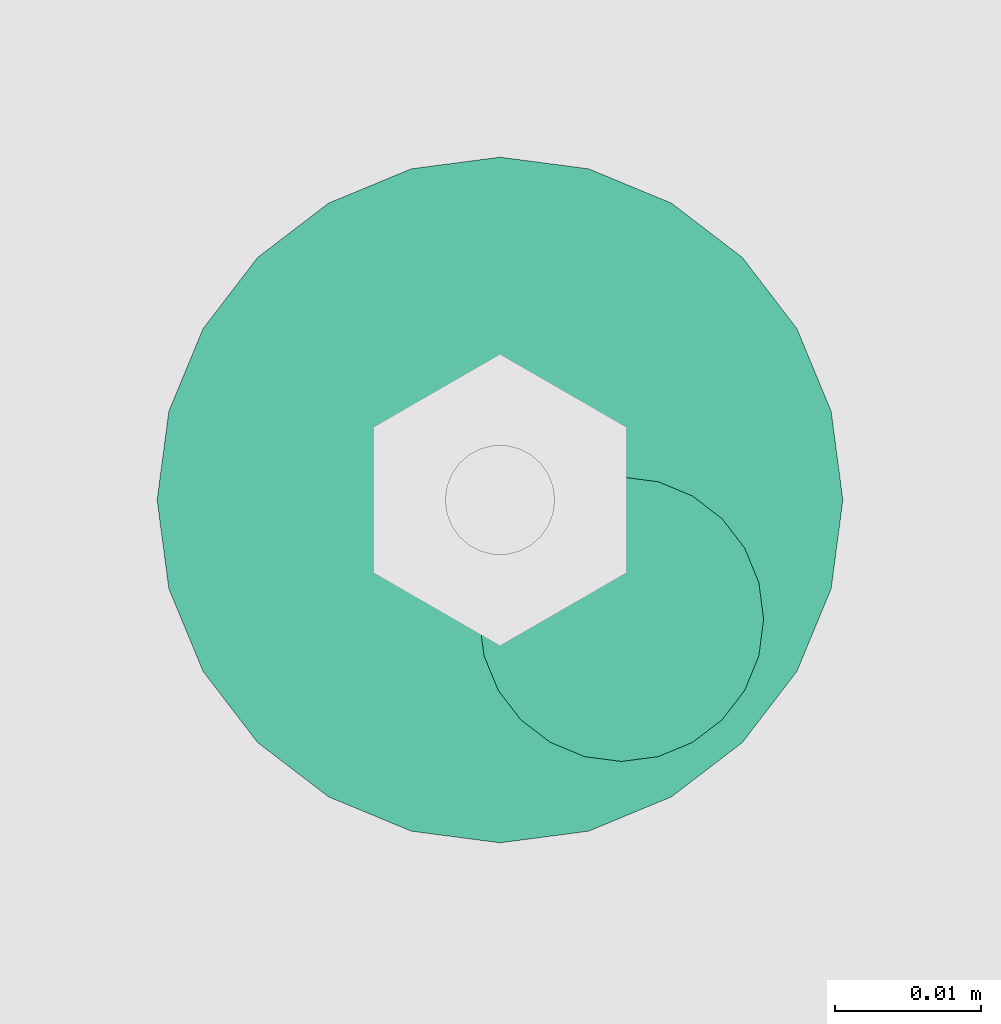
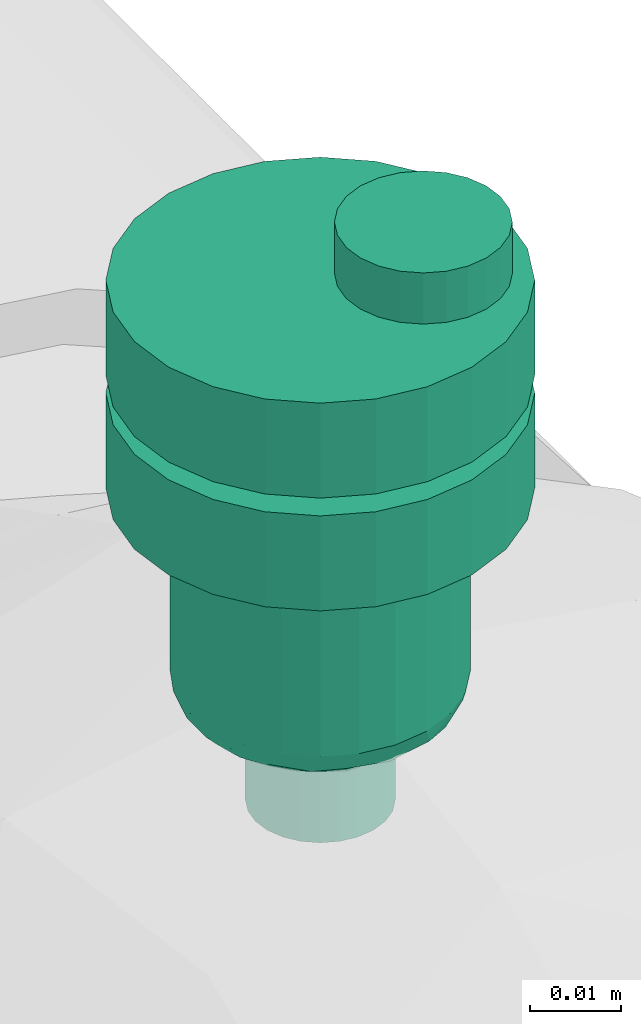
# One storey, part 3 of 6: 1 flow controller.
"""IFC2X3 building model written with IfcOpenShell, lengths in millimetres."""

from ifc_helpers import new_model, entity, si_unit, converted_unit, derived_unit, direction, frame, origin, place, context, subcontext, project, spatial, faceted_brep, source, transform, mapped, material, type_object, type_shapes, element, save


model = new_model("IFC2X3")

# Units and contexts
model_context = context("Model", 3, precision=0.01, world=origin(), true_north=direction((6.12303176911189e-17, 1.0)))
body_context = subcontext(model_context, "Body", "Model", "MODEL_VIEW")
ifc_project = project(units=[si_unit("LENGTHUNIT", "METRE", prefix="MILLI"), si_unit("AREAUNIT", "SQUARE_METRE"), si_unit("VOLUMEUNIT", "CUBIC_METRE"), converted_unit("PLANEANGLEUNIT", "DEGREE", entity("IfcRatioMeasure", 0.0174532925199433), si_unit("PLANEANGLEUNIT", "RADIAN"), dimensions=[0, 0, 0, 0, 0, 0, 0]), si_unit("MASSUNIT", "GRAM", prefix="KILO"), derived_unit("MASSDENSITYUNIT", [(si_unit("MASSUNIT", "GRAM", prefix="KILO"), 1), (si_unit("LENGTHUNIT", "METRE"), -3)]), derived_unit("MOMENTOFINERTIAUNIT", [(si_unit("LENGTHUNIT", "METRE"), 4)]), si_unit("TIMEUNIT", "SECOND"), si_unit("FREQUENCYUNIT", "HERTZ"), si_unit("THERMODYNAMICTEMPERATUREUNIT", "DEGREE_CELSIUS"), derived_unit("THERMALTRANSMITTANCEUNIT", [(si_unit("MASSUNIT", "GRAM", prefix="KILO"), 1), (si_unit("THERMODYNAMICTEMPERATUREUNIT", "KELVIN"), -1), (si_unit("TIMEUNIT", "SECOND"), -3)]), derived_unit("VOLUMETRICFLOWRATEUNIT", [(si_unit("LENGTHUNIT", "METRE"), 3), (si_unit("TIMEUNIT", "SECOND"), -1)]), derived_unit("MASSFLOWRATEUNIT", [(si_unit("MASSUNIT", "GRAM", prefix="KILO"), 1), (si_unit("TIMEUNIT", "SECOND"), -1)]), derived_unit("ROTATIONALFREQUENCYUNIT", [(si_unit("TIMEUNIT", "SECOND"), -1)]), si_unit("ELECTRICCURRENTUNIT", "AMPERE"), si_unit("ELECTRICVOLTAGEUNIT", "VOLT"), si_unit("POWERUNIT", "WATT"), si_unit("FORCEUNIT", "NEWTON", prefix="KILO"), si_unit("ILLUMINANCEUNIT", "LUX"), si_unit("LUMINOUSFLUXUNIT", "LUMEN"), si_unit("LUMINOUSINTENSITYUNIT", "CANDELA"), derived_unit("USERDEFINED", [(si_unit("MASSUNIT", "GRAM", prefix="KILO"), -1), (si_unit("LENGTHUNIT", "METRE"), -2), (si_unit("TIMEUNIT", "SECOND"), 3), (si_unit("LUMINOUSFLUXUNIT", "LUMEN"), 1)]), derived_unit("LINEARVELOCITYUNIT", [(si_unit("LENGTHUNIT", "METRE"), 1), (si_unit("TIMEUNIT", "SECOND"), -1)]), si_unit("PRESSUREUNIT", "PASCAL"), derived_unit("USERDEFINED", [(si_unit("LENGTHUNIT", "METRE"), -2), (si_unit("MASSUNIT", "GRAM", prefix="KILO"), 1), (si_unit("TIMEUNIT", "SECOND"), -2)]), derived_unit("LINEARFORCEUNIT", [(si_unit("MASSUNIT", "GRAM", prefix="KILO"), 1), (si_unit("LENGTHUNIT", "METRE"), 1), (si_unit("TIMEUNIT", "SECOND"), -2), (si_unit("LENGTHUNIT", "METRE"), -1)]), derived_unit("PLANARFORCEUNIT", [(si_unit("MASSUNIT", "GRAM", prefix="KILO"), 1), (si_unit("LENGTHUNIT", "METRE"), 1), (si_unit("TIMEUNIT", "SECOND"), -2), (si_unit("LENGTHUNIT", "METRE"), -2)])], contexts=[model_context])

# Site, building, storey
site_placement = place(None, origin())
site = spatial("IfcSite", under=ifc_project, at=site_placement, CompositionType="ELEMENT")
building_placement = place(site_placement, origin())
building = spatial("IfcBuilding", under=site, at=building_placement, CompositionType="ELEMENT")
storey_placement = place(building_placement, origin())
storey = spatial("IfcBuildingStorey", under=building, at=storey_placement, Name="01", CompositionType="ELEMENT", Elevation=0.0)

# Flow controller
ifc_material = material()
valve_type = type_object("IfcValveType", PredefinedType="NOTDEFINED", material=ifc_material)
shared_shape = source(origin(), body_context, "Body", "Brep", [
    faceted_brep([(-6.86, -13.27, -15.58), (-5.66, -12.77, -15.58), (-5.66, -12.77, -13.2), (-6.86, -13.27, -13.2), (-6.86, -13.27, -0.5), (-5.66, -12.77, -0.5), (-5.66, -12.77, 2.49), (-6.86, -13.27, 2.49), (-8.16, -13.44, -15.58), (-8.16, -13.44, -13.2), (-8.16, -13.44, -0.5), (-8.16, -13.44, 2.49), (-3.83, -10.94, -15.58), (-3.33, -9.74, -15.58), (-3.33, -9.74, -13.2), (-3.83, -10.94, -13.2), (-3.83, -10.94, -0.5), (-3.33, -9.74, -0.5), (-3.33, -9.74, 2.49), (-3.83, -10.94, 2.49), (-4.62, -11.98, -15.58), (-4.62, -11.98, -13.2), (-4.62, -11.98, -0.5), (-4.62, -11.98, 2.49), (-3.16, -8.44, -13.2), (-3.16, -8.44, -15.58), (-3.16, -8.44, 2.49), (-3.16, -8.44, -0.5), (-3.83, -5.94, -15.58), (-4.62, -4.91, -15.58), (-4.62, -4.91, -13.2), (-3.83, -5.94, -13.2), (-3.83, -5.94, -0.5), (-4.62, -4.91, -0.5), (-4.62, -4.91, 2.49), (-3.83, -5.94, 2.49), (-3.33, -7.15, -15.58), (-3.33, -7.15, -13.2), (-3.33, -7.15, -0.5), (-3.33, -7.15, 2.49), (-6.86, -3.61, -15.58), (-8.16, -3.44, -15.58), (-8.16, -3.44, -13.2), (-6.86, -3.61, -13.2), (-6.86, -3.61, -0.5), (-8.16, -3.44, -0.5), (-8.16, -3.44, 2.49), (-6.86, -3.61, 2.49), (-5.66, -4.11, -15.58), (-5.66, -4.11, -13.2), (-5.66, -4.11, -0.5), (-5.66, -4.11, 2.49), (-9.45, -3.61, -0.5), (-9.45, -3.61, 2.49), (-9.45, -3.61, -15.58), (-9.45, -3.61, -13.2), (-10.66, -4.11, -0.5), (-10.66, -4.11, 2.49), (-10.66, -4.11, -15.58), (-10.66, -4.11, -13.2), (-12.49, -5.94, 2.49), (-11.69, -4.91, 2.49), (-11.69, -4.91, -0.5), (-12.49, -5.94, -0.5), (-11.69, -4.91, -15.58), (-12.49, -5.94, -15.58), (-12.49, -5.94, -13.2), (-11.69, -4.91, -13.2), (-12.99, -7.15, 2.49), (-12.99, -7.15, -0.5), (-12.99, -7.15, -15.58), (-12.99, -7.15, -13.2), (-13.16, -8.44, 2.49), (-13.16, -8.44, -0.5), (-13.16, -8.44, -13.2), (-13.16, -8.44, -15.58), (-12.49, -10.94, -0.5), (-12.49, -10.94, 2.49), (-12.99, -9.74, 2.49), (-12.99, -9.74, -0.5), (-12.99, -9.74, -15.58), (-12.49, -10.94, -15.58), (-12.49, -10.94, -13.2), (-12.99, -9.74, -13.2), (-11.69, -11.98, -0.5), (-11.69, -11.98, 2.49), (-11.69, -11.98, -15.58), (-11.69, -11.98, -13.2), (-9.45, -13.27, 2.49), (-10.66, -12.77, 2.49), (-10.66, -12.77, -0.5), (-9.45, -13.27, -0.5), (-10.66, -12.77, -15.58), (-9.45, -13.27, -15.58), (-9.45, -13.27, -13.2), (-10.66, -12.77, -13.2), (6.08, -22.7, -0.5), (0.0, -23.5, -0.5), (11.75, -20.35, -0.5), (16.62, -16.62, -0.5), (20.35, -11.75, -0.5), (22.7, -6.08, -0.5), (23.5, 0.0, -0.5), (22.7, 6.08, -0.5), (20.35, 11.75, -0.5), (16.62, 16.62, -0.5), (11.75, 20.35, -0.5), (6.08, 22.7, -0.5), (0.0, 23.5, -0.5), (-6.08, 22.7, -0.5), (-11.75, 20.35, -0.5), (-16.62, 16.62, -0.5), (-20.35, 11.75, -0.5), (-22.7, 6.08, -0.5), (-23.5, 0.0, -0.5), (-22.7, -6.08, -0.5), (-20.35, -11.75, -0.5), (-16.62, -16.62, -0.5), (-11.75, -20.35, -0.5), (-6.08, -22.7, -0.5), (11.75, 20.35, -13.2), (6.08, 22.7, -13.2), (16.62, 16.62, -13.2), (20.35, 11.75, -13.2), (22.7, 6.08, -13.2), (23.5, 0.0, -13.2), (22.7, -6.08, -13.2), (20.35, -11.75, -13.2), (16.62, -16.62, -13.2), (11.75, -20.35, -13.2), (6.08, -22.7, -13.2), (0.0, -23.5, -13.2), (-6.08, -22.7, -13.2), (-11.75, -20.35, -13.2), (-16.62, -16.62, -13.2), (-20.35, -11.75, -13.2), (-22.7, -6.08, -13.2), (-23.5, 0.0, -13.2), (-22.7, 6.08, -13.2), (-20.35, 11.75, -13.2), (-16.62, 16.62, -13.2), (-11.75, 20.35, -13.2), (-6.08, 22.7, -13.2), (0.0, 23.5, -13.2), (-22.7, -6.08, -28.28), (-22.7, -6.08, -15.58), (-23.5, 0.0, -15.58), (-23.5, 0.0, -28.28), (-20.35, -11.75, -28.28), (-20.35, -11.75, -15.58), (-11.75, -20.35, -15.58), (-16.62, -16.62, -15.58), (-16.62, -16.62, -28.28), (-11.75, -20.35, -28.28), (-6.08, -22.7, -15.58), (-6.08, -22.7, -28.28), (0.0, -23.5, -15.58), (0.0, -23.5, -28.28), (6.08, -22.7, -28.28), (6.08, -22.7, -15.58), (11.75, -20.35, -28.28), (11.75, -20.35, -15.58), (20.35, -11.75, -15.58), (16.62, -16.62, -15.58), (16.62, -16.62, -28.28), (20.35, -11.75, -28.28), (22.7, -6.08, -15.58), (22.7, -6.08, -28.28), (23.5, 0.0, -15.58), (23.5, 0.0, -28.28), (22.7, 6.08, -28.28), (22.7, 6.08, -15.58), (20.35, 11.75, -28.28), (20.35, 11.75, -15.58), (11.75, 20.35, -15.58), (16.62, 16.62, -15.58), (16.62, 16.62, -28.28), (11.75, 20.35, -28.28), (6.08, 22.7, -15.58), (6.08, 22.7, -28.28), (0.0, 23.5, -15.58), (0.0, 23.5, -28.28), (-6.08, 22.7, -28.28), (-6.08, 22.7, -15.58), (-11.75, 20.35, -28.28), (-11.75, 20.35, -15.58), (-20.35, 11.75, -15.58), (-16.62, 16.62, -15.58), (-16.62, 16.62, -28.28), (-20.35, 11.75, -28.28), (-22.7, 6.08, -15.58), (-22.7, 6.08, -28.28), (8.23, 14.25, -28.28), (4.26, 15.89, -28.28), (11.63, 11.63, -28.28), (14.25, 8.22, -28.28), (15.89, 4.26, -28.28), (16.45, 0.0, -28.28), (15.89, -4.26, -28.28), (14.25, -8.23, -28.28), (11.63, -11.63, -28.28), (8.23, -14.25, -28.28), (4.26, -15.89, -28.28), (0.0, -16.45, -28.28), (-4.26, -15.89, -28.28), (-8.22, -14.25, -28.28), (-11.63, -11.63, -28.28), (-14.25, -8.23, -28.28), (-15.89, -4.26, -28.28), (-16.45, 0.0, -28.28), (-15.89, 4.26, -28.28), (-14.25, 8.22, -28.28), (-11.63, 11.63, -28.28), (-8.22, 14.25, -28.28), (-4.26, 15.89, -28.28), (0.0, 16.45, -28.28), (-15.89, -4.26, -52.7), (-16.45, 0.0, -52.7), (-14.25, -8.23, -52.7), (-11.63, -11.63, -52.7), (-8.22, -14.25, -52.7), (-4.26, -15.89, -52.7), (0.0, -16.45, -52.7), (4.26, -15.89, -52.7), (8.23, -14.25, -52.7), (11.63, -11.63, -52.7), (14.25, -8.23, -52.7), (15.89, -4.26, -52.7), (16.45, 0.0, -52.7), (15.89, 4.26, -52.7), (14.25, 8.22, -52.7), (11.63, 11.63, -52.7), (8.23, 14.25, -52.7), (4.26, 15.89, -52.7), (0.0, 16.45, -52.7), (-4.26, 15.89, -52.7), (-8.22, 14.25, -52.7), (-11.63, 11.63, -52.7), (-14.25, 8.22, -52.7), (-15.89, 4.26, -52.7), (10.61, 9.36, -56.39), (8.29, 11.45, -56.39), (9.98, 12.23, -54.94), (-13.58, 4.48, -56.31), (-14.89, 5.25, -54.94), (-12.77, 8.5, -55.51), (6.32, 14.92, -54.11), (-3.39, 14.2, -56.13), (-6.26, 13.77, -55.71), (-2.15, 15.69, -54.85), (2.15, 15.59, -55.0), (10.54, 4.37, -56.8), (12.15, 6.9, -56.46), (14.89, 5.25, -54.94), (13.8, 0.0, -56.2), (13.58, 4.48, -56.31), (12.77, 8.5, -55.51), (15.25, 0.0, -55.6), (-9.98, 12.23, -54.94), (6.26, 13.77, -55.71), (4.37, 10.54, -56.8), (3.28, 13.85, -56.34), (-15.25, 0.0, -55.6), (-6.32, 14.92, -54.11), (-10.54, 4.37, -56.8), (-12.35, 0.0, -56.8), (-12.15, 6.9, -56.46), (-10.61, 9.36, -56.39), (8.73, 8.73, -56.8), (-4.37, 10.54, -56.8), (-6.55, 9.64, -56.8), (-13.8, 0.0, -56.2), (-0.21, 14.49, -56.2), (0.0, 12.35, -56.8), (-8.73, 8.73, -56.8), (-8.29, 11.45, -56.39), (12.35, 0.0, -56.8), (-10.61, -9.36, -56.39), (-8.29, -11.45, -56.39), (-9.98, -12.23, -54.94), (13.58, -4.48, -56.31), (14.89, -5.25, -54.94), (12.77, -8.5, -55.51), (-6.32, -14.92, -54.11), (6.32, -14.92, -54.11), (9.98, -12.23, -54.94), (-2.15, -15.59, -55.0), (-10.54, -4.37, -56.8), (-12.15, -6.9, -56.46), (-12.77, -8.5, -55.51), (2.15, -15.69, -54.85), (-14.89, -5.25, -54.94), (-13.58, -4.48, -56.31), (-8.73, -8.73, -56.8), (6.26, -13.77, -55.71), (4.37, -10.54, -56.8), (6.55, -9.64, -56.8), (12.15, -6.9, -56.46), (10.61, -9.36, -56.39), (10.54, -4.37, -56.8), (-6.26, -13.77, -55.71), (-4.37, -10.54, -56.8), (-3.28, -13.85, -56.34), (3.39, -14.2, -56.13), (0.21, -14.49, -56.2), (0.0, -12.35, -56.8), (8.73, -8.73, -56.8), (8.29, -11.45, -56.39), (-7.94, 2.13, -56.8), (-8.22, 0.0, -56.8), (-7.12, 4.11, -56.8), (-7.94, -2.13, -56.8), (-7.12, -4.11, -56.8), (-5.82, -5.82, -56.8), (-4.11, -7.12, -56.8), (-2.13, -7.94, -56.8), (0.0, -8.23, -56.8), (2.13, -7.94, -56.8), (4.11, -7.12, -56.8), (5.82, -5.82, -56.8), (7.12, -4.11, -56.8), (7.94, -2.13, -56.8), (8.23, 0.0, -56.8), (7.94, 2.13, -56.8), (7.12, 4.11, -56.8), (5.82, 5.82, -56.8), (4.11, 7.12, -56.8), (2.13, 7.94, -56.8), (0.0, 8.22, -56.8), (-2.13, 7.94, -56.8), (-4.11, 7.12, -56.8), (-5.82, 5.82, -56.8), (0.0, 8.22, -70.0), (2.13, 7.94, -70.0), (4.11, 7.12, -70.0), (5.82, 5.82, -70.0), (7.12, 4.11, -70.0), (7.94, 2.13, -70.0), (8.23, 0.0, -70.0), (7.94, -2.13, -70.0), (7.12, -4.11, -70.0), (5.82, -5.82, -70.0), (4.11, -7.12, -70.0), (2.13, -7.94, -70.0), (0.0, -8.23, -70.0), (-2.13, -7.94, -70.0), (-4.11, -7.12, -70.0), (-5.82, -5.82, -70.0), (-7.12, -4.11, -70.0), (-7.94, -2.13, -70.0), (-8.22, 0.0, -70.0), (-7.94, 2.13, -70.0), (-7.12, 4.11, -70.0), (-5.82, 5.82, -70.0), (-4.11, 7.12, -70.0), (-2.13, 7.94, -70.0), (1.25, -5.8, 9.33), (0.27, -3.45, 9.33), (-1.28, -1.43, 9.33), (-3.3, 0.12, 9.33), (-5.65, 1.09, 9.33), (-8.17, 1.43, 9.33), (-10.69, 1.09, 9.33), (-13.05, 0.12, 9.33), (-15.07, -1.43, 9.33), (-16.61, -3.45, 9.33), (-17.59, -5.8, 9.33), (-17.92, -8.32, 9.33), (-17.59, -10.85, 9.33), (-16.61, -13.2, 9.33), (-15.07, -15.22, 9.33), (-13.05, -16.77, 9.33), (-10.69, -17.74, 9.33), (-8.17, -18.07, 9.33), (-5.65, -17.74, 9.33), (-3.3, -16.77, 9.33), (-1.28, -15.22, 9.33), (0.27, -13.2, 9.33), (1.25, -10.85, 9.33), (1.58, -8.32, 9.33), (-16.61, -3.45, 2.49), (-17.59, -5.8, 2.49), (-15.07, -1.43, 2.49), (-13.05, 0.12, 2.49), (-10.69, 1.09, 2.49), (-8.17, 1.43, 2.49), (-5.65, 1.09, 2.49), (-3.3, 0.12, 2.49), (-1.28, -1.43, 2.49), (0.27, -3.45, 2.49), (1.25, -5.8, 2.49), (1.58, -8.32, 2.49), (1.25, -10.85, 2.49), (0.27, -13.2, 2.49), (-1.28, -15.22, 2.49), (-3.3, -16.77, 2.49), (-5.65, -17.74, 2.49), (-8.17, -18.07, 2.49), (-10.69, -17.74, 2.49), (-13.05, -16.77, 2.49), (-15.07, -15.22, 2.49), (-16.61, -13.2, 2.49), (-17.59, -10.85, 2.49), (-17.92, -8.32, 2.49)], [[[0, 1, 2, 3]], [[4, 5, 6, 7]], [[8, 0, 3, 9]], [[10, 4, 7, 11]], [[12, 13, 14, 15]], [[16, 17, 18, 19]], [[20, 12, 15, 21]], [[22, 16, 19, 23]], [[1, 20, 21, 2]], [[5, 22, 23, 6]], [[24, 14, 13, 25]], [[26, 18, 17, 27]], [[28, 29, 30, 31]], [[32, 33, 34, 35]], [[36, 28, 31, 37]], [[38, 32, 35, 39]], [[40, 41, 42, 43]], [[44, 45, 46, 47]], [[48, 40, 43, 49]], [[50, 44, 47, 51]], [[29, 48, 49, 30]], [[33, 50, 51, 34]], [[36, 37, 24, 25]], [[38, 39, 26, 27]], [[52, 53, 46, 45]], [[41, 54, 55, 42]], [[56, 57, 53, 52]], [[54, 58, 59, 55]], [[60, 61, 62, 63]], [[64, 65, 66, 67]], [[56, 62, 61, 57]], [[58, 64, 67, 59]], [[68, 60, 63, 69]], [[65, 70, 71, 66]], [[72, 68, 69, 73]], [[74, 71, 70, 75]], [[76, 77, 78, 79]], [[80, 81, 82, 83]], [[84, 85, 77, 76]], [[81, 86, 87, 82]], [[88, 89, 90, 91]], [[92, 93, 94, 95]], [[84, 90, 89, 85]], [[86, 92, 95, 87]], [[11, 88, 91, 10]], [[93, 8, 9, 94]], [[79, 78, 72, 73]], [[80, 83, 74, 75]], [[96, 16, 97]], [[16, 96, 17]], [[98, 17, 96]], [[27, 17, 98]], [[98, 99, 27]], [[100, 27, 99]], [[100, 38, 27]], [[38, 100, 101]], [[38, 101, 102]], [[38, 102, 32]], [[32, 102, 103]], [[104, 32, 103]], [[104, 33, 32]], [[104, 105, 33]], [[105, 106, 33]], [[106, 50, 33]], [[50, 106, 107]], [[50, 107, 108]], [[108, 44, 50]], [[44, 108, 109]], [[44, 109, 110]], [[110, 45, 44]], [[45, 110, 111]], [[45, 111, 112]], [[52, 45, 112]], [[52, 112, 113]], [[56, 52, 113]], [[113, 114, 56]], [[114, 62, 56]], [[62, 114, 63]], [[114, 115, 63]], [[115, 69, 63]], [[73, 69, 115]], [[115, 116, 73]], [[116, 79, 73]], [[79, 116, 76]], [[76, 116, 117]], [[76, 117, 84]], [[117, 90, 84]], [[118, 90, 117]], [[90, 118, 91]], [[10, 91, 118]], [[10, 118, 119]], [[97, 5, 119]], [[119, 5, 4]], [[10, 119, 4]], [[22, 97, 16]], [[22, 5, 97]], [[120, 49, 121]], [[49, 120, 30]], [[122, 30, 120]], [[122, 123, 30]], [[30, 123, 31]], [[123, 124, 31]], [[31, 124, 125]], [[37, 31, 125]], [[37, 125, 126]], [[127, 37, 126]], [[37, 127, 24]], [[127, 128, 24]], [[129, 24, 128]], [[14, 24, 129]], [[129, 130, 14]], [[130, 15, 14]], [[130, 131, 15]], [[131, 21, 15]], [[2, 21, 131]], [[2, 131, 132]], [[2, 132, 3]], [[3, 132, 9]], [[132, 133, 9]], [[94, 9, 133]], [[133, 95, 94]], [[95, 133, 134]], [[95, 134, 87]], [[82, 87, 134]], [[135, 82, 134]], [[135, 83, 82]], [[74, 83, 135]], [[135, 136, 74]], [[74, 136, 71]], [[71, 136, 66]], [[66, 136, 137]], [[137, 67, 66]], [[67, 137, 59]], [[137, 138, 59]], [[59, 138, 55]], [[139, 55, 138]], [[55, 139, 42]], [[140, 42, 139]], [[141, 42, 140]], [[42, 141, 43]], [[141, 142, 43]], [[43, 142, 143]], [[121, 49, 143]], [[43, 143, 49]], [[136, 115, 114, 137]], [[144, 145, 146, 147]], [[135, 116, 115, 136]], [[148, 149, 145, 144]], [[118, 117, 134, 133]], [[150, 151, 152, 153]], [[135, 134, 117, 116]], [[148, 152, 151, 149]], [[119, 118, 133, 132]], [[154, 150, 153, 155]], [[97, 119, 132, 131]], [[156, 154, 155, 157]], [[130, 96, 97, 131]], [[158, 159, 156, 157]], [[129, 98, 96, 130]], [[160, 161, 159, 158]], [[100, 99, 128, 127]], [[162, 163, 164, 165]], [[129, 128, 99, 98]], [[160, 164, 163, 161]], [[101, 100, 127, 126]], [[166, 162, 165, 167]], [[102, 101, 126, 125]], [[168, 166, 167, 169]], [[124, 103, 102, 125]], [[170, 171, 168, 169]], [[123, 104, 103, 124]], [[172, 173, 171, 170]], [[106, 105, 122, 120]], [[174, 175, 176, 177]], [[123, 122, 105, 104]], [[172, 176, 175, 173]], [[107, 106, 120, 121]], [[178, 174, 177, 179]], [[108, 107, 121, 143]], [[180, 178, 179, 181]], [[142, 109, 108, 143]], [[182, 183, 180, 181]], [[141, 110, 109, 142]], [[184, 185, 183, 182]], [[112, 111, 140, 139]], [[186, 187, 188, 189]], [[141, 140, 111, 110]], [[184, 188, 187, 185]], [[113, 112, 139, 138]], [[190, 186, 189, 191]], [[114, 113, 138, 137]], [[146, 190, 191, 147]], [[159, 12, 156]], [[12, 159, 13]], [[161, 13, 159]], [[25, 13, 161]], [[161, 163, 25]], [[162, 25, 163]], [[162, 36, 25]], [[36, 162, 166]], [[36, 166, 168]], [[36, 168, 28]], [[28, 168, 171]], [[173, 28, 171]], [[173, 29, 28]], [[173, 175, 29]], [[175, 174, 29]], [[174, 48, 29]], [[48, 174, 178]], [[48, 178, 180]], [[180, 40, 48]], [[40, 180, 183]], [[40, 183, 185]], [[185, 41, 40]], [[41, 185, 187]], [[41, 187, 186]], [[54, 41, 186]], [[54, 186, 190]], [[58, 54, 190]], [[190, 146, 58]], [[146, 64, 58]], [[64, 146, 65]], [[146, 145, 65]], [[145, 70, 65]], [[75, 70, 145]], [[145, 149, 75]], [[149, 80, 75]], [[80, 149, 81]], [[81, 149, 151]], [[81, 151, 86]], [[151, 92, 86]], [[150, 92, 151]], [[92, 150, 93]], [[8, 93, 150]], [[8, 150, 154]], [[156, 1, 154]], [[154, 1, 0]], [[8, 154, 0]], [[20, 156, 12]], [[20, 1, 156]], [[177, 176, 192]], [[177, 192, 193]], [[193, 179, 177]], [[192, 176, 194]], [[172, 194, 176]], [[195, 194, 172]], [[196, 195, 172]], [[196, 172, 170]], [[196, 170, 197]], [[197, 170, 169]], [[198, 197, 169]], [[198, 169, 167]], [[199, 198, 167]], [[199, 167, 165]], [[200, 199, 165]], [[165, 164, 200]], [[164, 201, 200]], [[201, 164, 160]], [[201, 160, 202]], [[158, 202, 160]], [[202, 158, 203]], [[203, 158, 157]], [[157, 204, 203]], [[204, 157, 155]], [[204, 155, 205]], [[153, 205, 155]], [[153, 206, 205]], [[153, 152, 206]], [[207, 206, 152]], [[148, 207, 152]], [[144, 207, 148]], [[208, 207, 144]], [[208, 144, 147]], [[147, 209, 208]], [[191, 209, 147]], [[191, 210, 209]], [[210, 191, 189]], [[211, 210, 189]], [[211, 189, 188]], [[211, 188, 212]], [[188, 184, 212]], [[212, 184, 213]], [[213, 184, 182]], [[182, 214, 213]], [[181, 214, 182]], [[179, 215, 181]], [[214, 181, 215]], [[179, 193, 215]], [[216, 208, 209, 217]], [[218, 207, 208, 216]], [[205, 206, 219, 220]], [[218, 219, 206, 207]], [[204, 205, 220, 221]], [[221, 222, 203, 204]], [[202, 223, 224, 201]], [[225, 200, 201, 224]], [[199, 226, 227, 198]], [[225, 226, 199, 200]], [[198, 227, 228, 197]], [[223, 202, 203, 222]], [[229, 196, 197, 228]], [[230, 195, 196, 229]], [[192, 194, 231, 232]], [[230, 231, 194, 195]], [[193, 192, 232, 233]], [[193, 233, 234, 215]], [[214, 235, 236, 213]], [[237, 212, 213, 236]], [[211, 238, 239, 210]], [[237, 238, 211, 212]], [[210, 239, 217, 209]], [[235, 214, 215, 234]], [[240, 241, 242]], [[243, 244, 245]], [[246, 233, 232]], [[247, 248, 249]], [[233, 246, 250]], [[251, 240, 252]], [[253, 254, 255]], [[231, 256, 242]], [[229, 257, 253]], [[228, 257, 229]], [[230, 253, 256]], [[253, 255, 256]], [[229, 253, 230]], [[236, 258, 237]], [[242, 232, 231]], [[259, 260, 261]], [[249, 234, 250]], [[262, 239, 244]], [[230, 256, 231]], [[235, 263, 236]], [[244, 239, 238]], [[243, 264, 265]], [[263, 258, 236]], [[241, 260, 259]], [[234, 249, 235]], [[245, 244, 238]], [[233, 250, 234]], [[258, 245, 237]], [[266, 267, 264]], [[238, 237, 245]], [[240, 251, 268]], [[248, 269, 270]], [[262, 217, 239]], [[243, 271, 244]], [[246, 242, 259]], [[258, 267, 245]], [[240, 256, 252]], [[240, 242, 256]], [[247, 249, 272]], [[263, 249, 248]], [[273, 272, 261]], [[272, 249, 250]], [[274, 267, 275]], [[270, 274, 275]], [[241, 240, 268]], [[275, 258, 248]], [[264, 267, 274]], [[261, 272, 250]], [[247, 273, 269]], [[259, 261, 250]], [[273, 261, 260]], [[273, 247, 272]], [[269, 248, 247]], [[266, 245, 267]], [[251, 255, 276]], [[254, 253, 257]], [[254, 276, 255]], [[271, 262, 244]], [[243, 265, 271]], [[260, 241, 268]], [[242, 241, 259]], [[258, 275, 267]], [[270, 275, 248]], [[242, 246, 232]], [[250, 246, 259]], [[249, 263, 235]], [[258, 263, 248]], [[256, 255, 252]], [[255, 251, 252]], [[264, 243, 266]], [[243, 245, 266]], [[277, 278, 279]], [[280, 281, 282]], [[283, 221, 220]], [[284, 285, 224]], [[221, 283, 286]], [[287, 277, 288]], [[277, 289, 288]], [[219, 289, 279]], [[290, 222, 286]], [[217, 262, 216]], [[218, 291, 289]], [[291, 292, 289]], [[277, 287, 293]], [[216, 291, 218]], [[279, 220, 219]], [[294, 295, 296]], [[224, 285, 225]], [[257, 227, 281]], [[297, 298, 299]], [[226, 281, 227]], [[226, 225, 282]], [[291, 271, 292]], [[227, 257, 228]], [[226, 282, 281]], [[277, 279, 289]], [[218, 289, 219]], [[300, 301, 302]], [[290, 223, 222]], [[280, 254, 281]], [[223, 284, 224]], [[285, 282, 225]], [[221, 286, 222]], [[278, 301, 300]], [[303, 294, 290]], [[216, 262, 291]], [[285, 298, 282]], [[283, 279, 300]], [[280, 299, 276]], [[303, 290, 304]], [[284, 290, 294]], [[305, 304, 302]], [[304, 290, 286]], [[306, 298, 307]], [[296, 306, 307]], [[278, 277, 293]], [[307, 285, 294]], [[299, 298, 306]], [[302, 304, 286]], [[303, 305, 295]], [[300, 302, 286]], [[305, 302, 301]], [[305, 303, 304]], [[295, 294, 303]], [[297, 282, 298]], [[287, 292, 265]], [[271, 291, 262]], [[271, 265, 292]], [[254, 257, 281]], [[280, 276, 254]], [[301, 278, 293]], [[279, 278, 300]], [[285, 307, 298]], [[296, 307, 294]], [[279, 283, 220]], [[286, 283, 300]], [[290, 284, 223]], [[285, 284, 294]], [[289, 292, 288]], [[292, 287, 288]], [[299, 280, 297]], [[280, 282, 297]], [[308, 309, 265]], [[308, 265, 264]], [[308, 264, 274]], [[310, 308, 274]], [[311, 265, 309]], [[311, 287, 265]], [[311, 293, 287]], [[312, 293, 311]], [[312, 313, 293]], [[313, 314, 293]], [[314, 301, 293]], [[314, 305, 301]], [[305, 314, 315]], [[315, 316, 305]], [[316, 317, 305]], [[318, 305, 317]], [[318, 295, 305]], [[318, 296, 295]], [[318, 306, 296]], [[319, 306, 318]], [[320, 306, 319]], [[306, 320, 321]], [[321, 299, 306]], [[321, 276, 299]], [[322, 276, 321]], [[323, 276, 322]], [[323, 251, 276]], [[323, 268, 251]], [[323, 324, 268]], [[324, 325, 268]], [[268, 325, 326]], [[326, 260, 268]], [[326, 273, 260]], [[326, 327, 273]], [[328, 273, 327]], [[328, 329, 273]], [[329, 330, 273]], [[330, 331, 274]], [[330, 274, 270]], [[330, 270, 269]], [[330, 269, 273]], [[310, 274, 331]], [[332, 333, 334, 335, 336, 337, 338, 339, 340, 341, 342, 343, 344, 345, 346, 347, 348, 349, 350, 351, 352, 353, 354, 355]], [[349, 311, 309, 350]], [[348, 312, 311, 349]], [[314, 313, 347, 346]], [[348, 347, 313, 312]], [[315, 314, 346, 345]], [[316, 315, 345, 344]], [[343, 317, 316, 344]], [[342, 318, 317, 343]], [[320, 319, 341, 340]], [[342, 341, 319, 318]], [[321, 320, 340, 339]], [[322, 321, 339, 338]], [[337, 323, 322, 338]], [[336, 324, 323, 337]], [[326, 325, 335, 334]], [[336, 335, 325, 324]], [[327, 326, 334, 333]], [[328, 327, 333, 332]], [[355, 329, 328, 332]], [[354, 330, 329, 355]], [[310, 331, 353, 352]], [[354, 353, 331, 330]], [[308, 310, 352, 351]], [[309, 308, 351, 350]], [[356, 357, 358, 359, 360, 361, 362, 363, 364, 365, 366, 367, 368, 369, 370, 371, 372, 373, 374, 375, 376, 377, 378, 379]], [[380, 60, 381]], [[60, 380, 61]], [[382, 61, 380]], [[61, 382, 57]], [[382, 383, 57]], [[53, 57, 383]], [[384, 53, 383]], [[53, 384, 46]], [[46, 384, 385]], [[386, 46, 385]], [[46, 386, 47]], [[386, 387, 47]], [[51, 47, 387]], [[388, 51, 387]], [[388, 34, 51]], [[388, 389, 34]], [[389, 35, 34]], [[389, 390, 35]], [[39, 35, 390]], [[39, 390, 391]], [[39, 391, 26]], [[392, 26, 391]], [[18, 26, 392]], [[18, 392, 393]], [[19, 18, 393]], [[19, 393, 394]], [[23, 19, 394]], [[394, 395, 23]], [[395, 6, 23]], [[396, 6, 395]], [[396, 7, 6]], [[7, 396, 397]], [[7, 397, 11]], [[11, 397, 88]], [[398, 88, 397]], [[88, 398, 89]], [[89, 398, 399]], [[89, 399, 85]], [[399, 400, 85]], [[85, 400, 77]], [[401, 77, 400]], [[77, 401, 78]], [[402, 78, 401]], [[402, 72, 78]], [[72, 402, 403]], [[403, 381, 68]], [[403, 68, 72]], [[60, 68, 381]], [[396, 374, 373, 397]], [[395, 375, 374, 396]], [[377, 376, 394, 393]], [[395, 394, 376, 375]], [[378, 377, 393, 392]], [[379, 378, 392, 391]], [[390, 356, 379, 391]], [[389, 357, 356, 390]], [[359, 358, 388, 387]], [[389, 388, 358, 357]], [[360, 359, 387, 386]], [[361, 360, 386, 385]], [[384, 362, 361, 385]], [[383, 363, 362, 384]], [[365, 364, 382, 380]], [[383, 382, 364, 363]], [[366, 365, 380, 381]], [[367, 366, 381, 403]], [[402, 368, 367, 403]], [[401, 369, 368, 402]], [[371, 370, 400, 399]], [[401, 400, 370, 369]], [[372, 371, 399, 398]], [[373, 372, 398, 397]]]),
])
type_shapes(valve_type, [shared_shape])
flow_controller_placement = place(storey_placement, frame((31080.0, 10422.33, 31179.5), z_axis=(-1.01369679116909e-07, 0.0, 1.0), x_axis=(0.0, 1.0, 0.0)))
element("IfcFlowController", 1, at=flow_controller_placement, inside=storey, type_object=valve_type, material=ifc_material, context=body_context, shape_type="MappedRepresentation", body=[
    mapped(shared_shape, transform((0.0, 0.0, 0.0), scale=1.0)),
])

save(model, "model.ifc")
